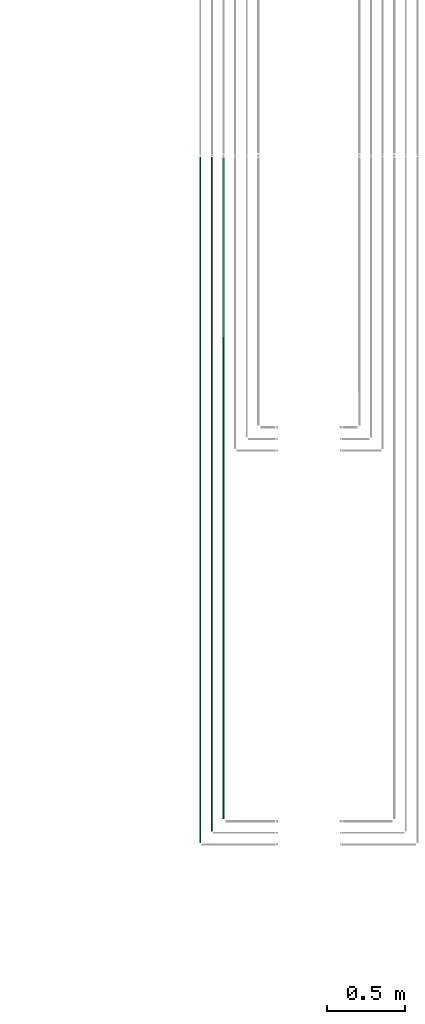
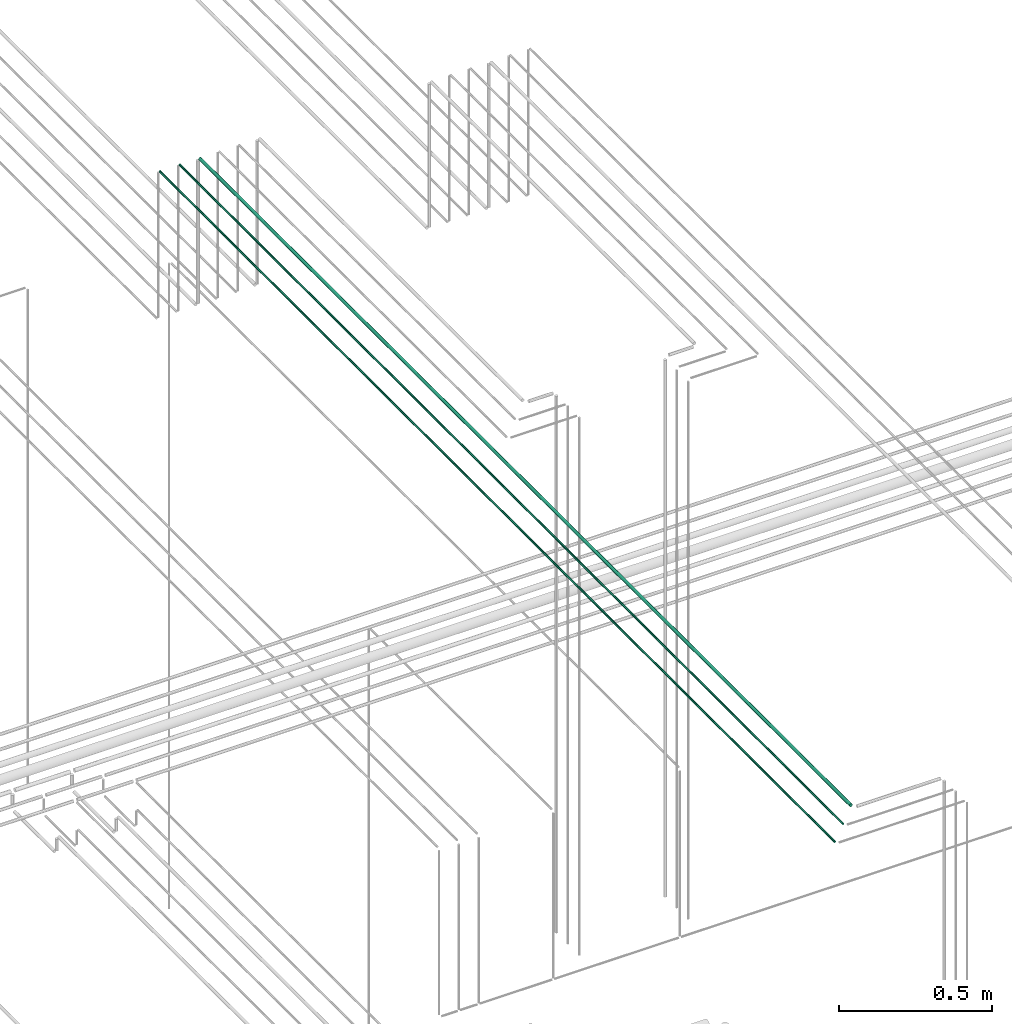
# One storey, part 57 of 331: 3 flow segments.
"""IFC2X3 building model written with IfcOpenShell, lengths in millimetres."""

from ifc_helpers import new_model, entity, si_unit, converted_unit, derived_unit, direction, frame, origin, origin_2d_with_axis, place, context, subcontext, project, spatial, circle, extrude, type_object, element, save


model = new_model("IFC2X3")

# Units and contexts
model_context = context("Model", 3, precision=0.01, world=origin(), true_north=direction((6.12303176911189e-17, 1.0)))
body_context = subcontext(model_context, "Body", "Model", "MODEL_VIEW")
ifc_project = project(units=[si_unit("LENGTHUNIT", "METRE", prefix="MILLI"), si_unit("AREAUNIT", "SQUARE_METRE"), si_unit("VOLUMEUNIT", "CUBIC_METRE"), converted_unit("PLANEANGLEUNIT", "DEGREE", entity("IfcRatioMeasure", 0.0174532925199433), si_unit("PLANEANGLEUNIT", "RADIAN"), dimensions=[0, 0, 0, 0, 0, 0, 0]), si_unit("MASSUNIT", "GRAM", prefix="KILO"), derived_unit("MASSDENSITYUNIT", [(si_unit("MASSUNIT", "GRAM", prefix="KILO"), 1), (si_unit("LENGTHUNIT", "METRE"), -3)]), derived_unit("MOMENTOFINERTIAUNIT", [(si_unit("LENGTHUNIT", "METRE"), 4)]), si_unit("TIMEUNIT", "SECOND"), si_unit("FREQUENCYUNIT", "HERTZ"), si_unit("THERMODYNAMICTEMPERATUREUNIT", "DEGREE_CELSIUS"), derived_unit("THERMALTRANSMITTANCEUNIT", [(si_unit("MASSUNIT", "GRAM", prefix="KILO"), 1), (si_unit("THERMODYNAMICTEMPERATUREUNIT", "KELVIN"), -1), (si_unit("TIMEUNIT", "SECOND"), -3)]), derived_unit("VOLUMETRICFLOWRATEUNIT", [(si_unit("LENGTHUNIT", "METRE"), 3), (si_unit("TIMEUNIT", "SECOND"), -1)]), derived_unit("MASSFLOWRATEUNIT", [(si_unit("MASSUNIT", "GRAM", prefix="KILO"), 1), (si_unit("TIMEUNIT", "SECOND"), -1)]), derived_unit("ROTATIONALFREQUENCYUNIT", [(si_unit("TIMEUNIT", "SECOND"), -1)]), si_unit("ELECTRICCURRENTUNIT", "AMPERE"), si_unit("ELECTRICVOLTAGEUNIT", "VOLT"), si_unit("POWERUNIT", "WATT"), si_unit("FORCEUNIT", "NEWTON", prefix="KILO"), si_unit("ILLUMINANCEUNIT", "LUX"), si_unit("LUMINOUSFLUXUNIT", "LUMEN"), si_unit("LUMINOUSINTENSITYUNIT", "CANDELA"), derived_unit("USERDEFINED", [(si_unit("MASSUNIT", "GRAM", prefix="KILO"), -1), (si_unit("LENGTHUNIT", "METRE"), -2), (si_unit("TIMEUNIT", "SECOND"), 3), (si_unit("LUMINOUSFLUXUNIT", "LUMEN"), 1)]), derived_unit("LINEARVELOCITYUNIT", [(si_unit("LENGTHUNIT", "METRE"), 1), (si_unit("TIMEUNIT", "SECOND"), -1)]), si_unit("PRESSUREUNIT", "PASCAL"), derived_unit("USERDEFINED", [(si_unit("LENGTHUNIT", "METRE"), -2), (si_unit("MASSUNIT", "GRAM", prefix="KILO"), 1), (si_unit("TIMEUNIT", "SECOND"), -2)]), derived_unit("LINEARFORCEUNIT", [(si_unit("MASSUNIT", "GRAM", prefix="KILO"), 1), (si_unit("LENGTHUNIT", "METRE"), 1), (si_unit("TIMEUNIT", "SECOND"), -2), (si_unit("LENGTHUNIT", "METRE"), -1)]), derived_unit("PLANARFORCEUNIT", [(si_unit("MASSUNIT", "GRAM", prefix="KILO"), 1), (si_unit("LENGTHUNIT", "METRE"), 1), (si_unit("TIMEUNIT", "SECOND"), -2), (si_unit("LENGTHUNIT", "METRE"), -2)])], contexts=[model_context])

# Site, building, storey
site_placement = place(None, frame((0.0, -0.00077364408347762, 0.0)))
site = spatial("IfcSite", under=ifc_project, at=site_placement, CompositionType="ELEMENT")
building_placement = place(site_placement, origin())
building = spatial("IfcBuilding", under=site, at=building_placement, CompositionType="ELEMENT")
storey_placement = place(building_placement, origin())
storey = spatial("IfcBuildingStorey", under=building, at=storey_placement, CompositionType="ELEMENT", Elevation=0.0)

# Flow segments
pipe_segment_type = type_object("IfcPipeSegmentType", PredefinedType="NOTDEFINED")
flow_segment_1_placement = place(storey_placement, frame((52812.4468045266, 1365.48876707966, 19042.4047277641)))
element("IfcFlowSegment", 1, at=flow_segment_1_placement, inside=storey, type_object=pipe_segment_type, context=body_context, shape_type="SweptSolid", body=[
    extrude(circle(Radius=6.0, at=origin_2d_with_axis()), frame((7.59527223591454, 0.0, 7.5952722359167), z_axis=(0.0, 1.0, 0.0), x_axis=(1.0, 0.0, 0.0)), (0.0, 0.0, 1.0), 4264.13179674766),
])
flow_segment_2_placement = place(storey_placement, frame((52739.4468045266, 1286.48876707966, 19044.4047277641)))
element("IfcFlowSegment", 2, at=flow_segment_2_placement, inside=storey, type_object=pipe_segment_type, context=body_context, shape_type="SweptSolid", body=[
    extrude(circle(Radius=4.0, at=origin_2d_with_axis()), frame((5.59527223591499, 0.0, 5.59527223591499), z_axis=(0.0, 1.0, 0.0), x_axis=(1.0, 0.0, 0.0)), (0.0, 0.0, 1.0), 4347.13179674766),
])
flow_segment_3_placement = place(storey_placement, frame((52664.4468045266, 1211.48876707966, 19044.4047277641)))
element("IfcFlowSegment", 3, at=flow_segment_3_placement, inside=storey, type_object=pipe_segment_type, context=body_context, shape_type="SweptSolid", body=[
    extrude(circle(Radius=4.0, at=origin_2d_with_axis()), frame((5.59527223591499, 0.0, 5.59527223591499), z_axis=(0.0, 1.0, 0.0), x_axis=(1.0, 0.0, 0.0)), (0.0, 0.0, 1.0), 4422.13179674766),
])

save(model, "model.ifc")
